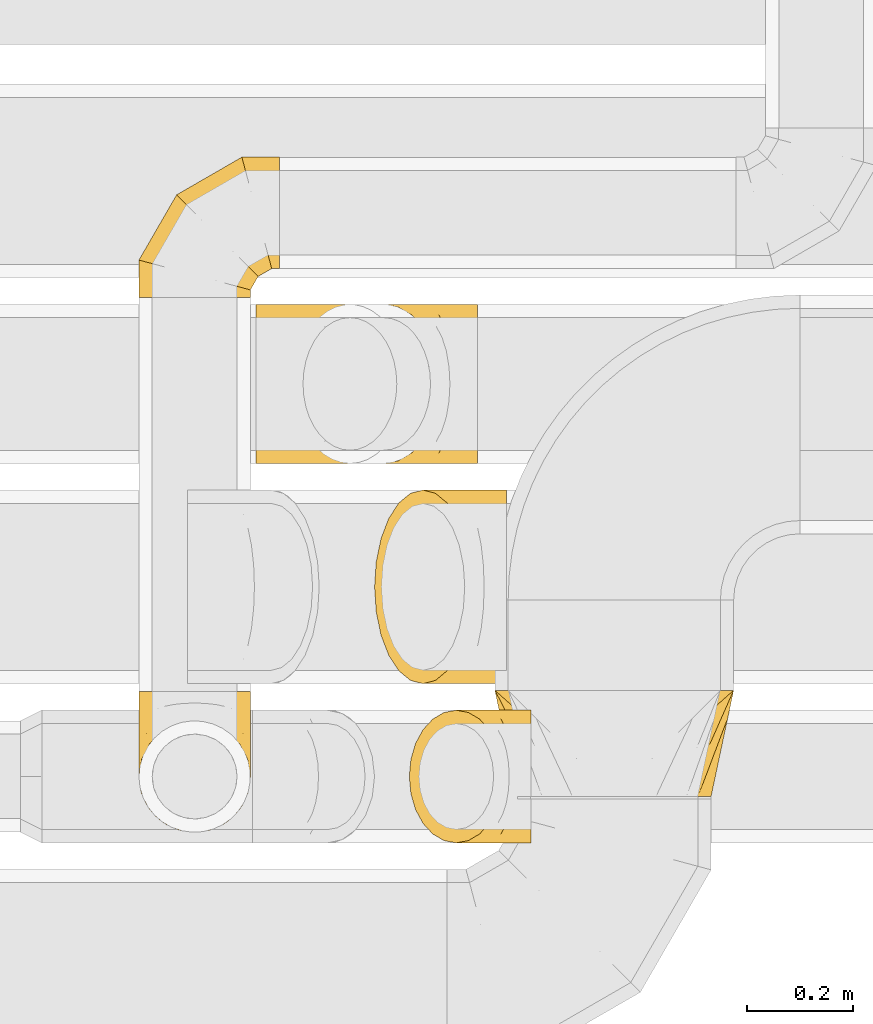
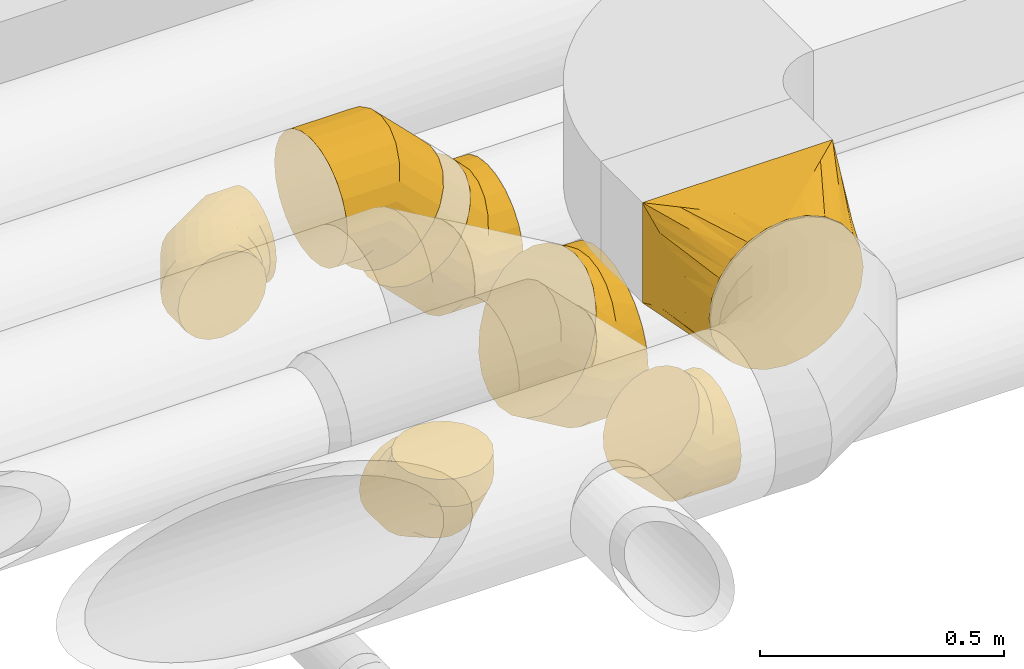
# One storey, part 18 of 92: 7 coverings.
"""IFC2X3 building model written with IfcOpenShell, lengths in millimetres."""

from ifc_helpers import new_model, entity, si_unit, converted_unit, derived_unit, direction, frame, origin, place, context, subcontext, project, spatial, faceted_brep, element, save


model = new_model("IFC2X3")

# Units and contexts
model_context = context("Model", 3, precision=0.01, world=origin(), true_north=direction((6.12303176911189e-17, 1.0)))
body_context = subcontext(model_context, "Body", "Model", "MODEL_VIEW")
ifc_project = project(units=[si_unit("LENGTHUNIT", "METRE", prefix="MILLI"), si_unit("AREAUNIT", "SQUARE_METRE"), si_unit("VOLUMEUNIT", "CUBIC_METRE"), converted_unit("PLANEANGLEUNIT", "DEGREE", entity("IfcRatioMeasure", 0.0174532925199433), si_unit("PLANEANGLEUNIT", "RADIAN"), dimensions=[0, 0, 0, 0, 0, 0, 0]), si_unit("MASSUNIT", "GRAM", prefix="KILO"), derived_unit("MASSDENSITYUNIT", [(si_unit("MASSUNIT", "GRAM", prefix="KILO"), 1), (si_unit("LENGTHUNIT", "METRE"), -3)]), derived_unit("MOMENTOFINERTIAUNIT", [(si_unit("LENGTHUNIT", "METRE"), 4)]), si_unit("TIMEUNIT", "SECOND"), si_unit("FREQUENCYUNIT", "HERTZ"), si_unit("THERMODYNAMICTEMPERATUREUNIT", "DEGREE_CELSIUS"), derived_unit("THERMALTRANSMITTANCEUNIT", [(si_unit("MASSUNIT", "GRAM", prefix="KILO"), 1), (si_unit("THERMODYNAMICTEMPERATUREUNIT", "KELVIN"), -1), (si_unit("TIMEUNIT", "SECOND"), -3)]), derived_unit("VOLUMETRICFLOWRATEUNIT", [(si_unit("LENGTHUNIT", "METRE"), 3), (si_unit("TIMEUNIT", "SECOND"), -1)]), derived_unit("MASSFLOWRATEUNIT", [(si_unit("MASSUNIT", "GRAM", prefix="KILO"), 1), (si_unit("TIMEUNIT", "SECOND"), -1)]), derived_unit("ROTATIONALFREQUENCYUNIT", [(si_unit("TIMEUNIT", "SECOND"), -1)]), si_unit("ELECTRICCURRENTUNIT", "AMPERE"), si_unit("ELECTRICVOLTAGEUNIT", "VOLT"), si_unit("POWERUNIT", "WATT"), si_unit("FORCEUNIT", "NEWTON", prefix="KILO"), si_unit("ILLUMINANCEUNIT", "LUX"), si_unit("LUMINOUSFLUXUNIT", "LUMEN"), si_unit("LUMINOUSINTENSITYUNIT", "CANDELA"), derived_unit("USERDEFINED", [(si_unit("MASSUNIT", "GRAM", prefix="KILO"), -1), (si_unit("LENGTHUNIT", "METRE"), -2), (si_unit("TIMEUNIT", "SECOND"), 3), (si_unit("LUMINOUSFLUXUNIT", "LUMEN"), 1)]), derived_unit("LINEARVELOCITYUNIT", [(si_unit("LENGTHUNIT", "METRE"), 1), (si_unit("TIMEUNIT", "SECOND"), -1)]), si_unit("PRESSUREUNIT", "PASCAL"), derived_unit("USERDEFINED", [(si_unit("LENGTHUNIT", "METRE"), -2), (si_unit("MASSUNIT", "GRAM", prefix="KILO"), 1), (si_unit("TIMEUNIT", "SECOND"), -2)]), derived_unit("LINEARFORCEUNIT", [(si_unit("MASSUNIT", "GRAM", prefix="KILO"), 1), (si_unit("LENGTHUNIT", "METRE"), 1), (si_unit("TIMEUNIT", "SECOND"), -2), (si_unit("LENGTHUNIT", "METRE"), -1)]), derived_unit("PLANARFORCEUNIT", [(si_unit("MASSUNIT", "GRAM", prefix="KILO"), 1), (si_unit("LENGTHUNIT", "METRE"), 1), (si_unit("TIMEUNIT", "SECOND"), -2), (si_unit("LENGTHUNIT", "METRE"), -2)])], contexts=[model_context])

# Site, building, storey
site_placement = place(None, origin())
site = spatial("IfcSite", under=ifc_project, at=site_placement, CompositionType="ELEMENT")
building_placement = place(site_placement, origin())
building = spatial("IfcBuilding", under=site, at=building_placement, CompositionType="ELEMENT")
storey_placement = place(building_placement, frame((0.0, 0.0, 4200.0)))
storey = spatial("IfcBuildingStorey", under=building, at=storey_placement, CompositionType="ELEMENT", Elevation=4200.0)

# Coverings
covering_1_placement = place(storey_placement, frame((46995.11, 14562.0, 3115.9)))
element("IfcCovering", 1, at=covering_1_placement, inside=storey, PredefinedType="INSULATION", context=body_context, shape_type="Brep", body=[
    faceted_brep([(316.25, 0.0, 342.14), (294.24, 0.0, 351.26), (272.23, 0.0, 360.38), (257.36, 0.0, 362.33), (242.49, 0.0, 364.29), (225.0, 0.0, 366.6), (207.51, 0.0, 364.29), (192.64, 0.0, 362.33), (177.77, 0.0, 360.38), (155.76, 0.0, 351.26), (133.75, 0.0, 342.14), (114.85, 0.0, 327.64), (95.95, 0.0, 313.14), (81.45, 0.0, 294.24), (66.95, 0.0, 275.35), (57.83, 0.0, 253.34), (48.72, 0.0, 231.33), (46.76, 0.0, 216.46), (44.8, 0.0, 201.59), (42.5, 0.0, 184.1), (44.8, 0.0, 166.6), (46.76, 0.0, 151.73), (48.72, 0.0, 136.86), (57.83, 0.0, 114.85), (66.95, 0.0, 92.85), (81.45, 0.0, 73.95), (95.95, 0.0, 55.05), (114.85, 0.0, 40.55), (133.75, 0.0, 26.05), (155.76, 0.0, 16.93), (177.77, 0.0, 7.81), (192.64, 0.0, 5.86), (207.51, 0.0, 3.9), (225.0, 0.0, 1.6), (242.49, 0.0, 3.9), (257.36, 0.0, 5.86), (272.23, 0.0, 7.81), (294.24, 0.0, 16.93), (316.25, 0.0, 26.05), (335.15, 0.0, 40.55), (354.05, 0.0, 55.05), (368.55, 0.0, 73.95), (383.05, 0.0, 92.85), (392.17, 0.0, 114.85), (401.28, 0.0, 136.86), (403.24, 0.0, 151.73), (405.2, 0.0, 166.6), (407.5, 0.0, 184.1), (405.2, 0.0, 201.59), (403.24, 0.0, 216.46), (401.28, 0.0, 231.33), (392.17, 0.0, 253.34), (383.05, 0.0, 275.35), (368.55, 0.0, 294.24), (354.05, 0.0, 313.14), (335.15, 0.0, 327.64), (450.0, 200.0, 366.6), (450.0, 200.0, 116.6), (0.0, 200.0, 116.6), (0.0, 200.0, 366.6), (305.9, 71.91, 42.95), (332.87, 95.89, 56.73), (362.15, 121.91, 71.7), (398.0, 100.0, 82.03), (420.72, 173.97, 101.63), (438.94, 147.94, 134.16), (444.47, 173.97, 125.38), (433.41, 121.91, 142.95), (427.88, 95.89, 151.73), (422.78, 71.91, 159.82), (251.97, 23.97, 15.38), (278.94, 47.94, 29.16), (417.69, 47.94, 167.91), (412.59, 23.97, 176.0), (391.44, 147.94, 86.66), (444.47, 173.97, 342.84), (438.94, 147.94, 319.09), (433.41, 121.91, 295.34), (427.88, 95.89, 271.59), (422.78, 71.91, 249.72), (417.69, 47.94, 227.84), (412.59, 23.97, 205.97), (405.81, 100.0, 335.85), (391.44, 147.94, 366.6), (420.72, 173.97, 366.6), (362.15, 121.91, 366.6), (332.87, 95.89, 366.6), (305.9, 71.91, 366.6), (278.94, 47.94, 366.6), (251.97, 23.97, 366.6), (29.28, 173.97, 366.6), (58.56, 147.94, 366.6), (87.85, 121.91, 366.6), (117.13, 95.89, 366.6), (144.1, 71.91, 366.6), (171.06, 47.94, 366.6), (198.03, 23.97, 366.6), (52.0, 100.0, 343.66), (11.06, 147.94, 319.09), (5.53, 173.97, 342.84), (16.59, 121.91, 295.34), (22.12, 95.89, 271.59), (27.22, 71.91, 249.72), (32.31, 47.94, 227.84), (37.41, 23.97, 205.97), (5.53, 173.97, 125.38), (11.06, 147.94, 134.16), (16.59, 121.91, 142.95), (22.12, 95.89, 151.73), (27.22, 71.91, 159.82), (32.31, 47.94, 167.91), (37.41, 23.97, 176.0), (44.19, 100.0, 89.85), (58.56, 147.94, 86.66), (29.28, 173.97, 101.63), (87.85, 121.91, 71.7), (117.13, 95.89, 56.73), (144.1, 71.91, 42.95), (171.06, 47.94, 29.16), (198.03, 23.97, 15.38)], [[[0, 1, 2, 3, 4, 5, 6, 7, 8, 9, 10, 11, 12, 13, 14, 15, 16, 17, 18, 19, 20, 21, 22, 23, 24, 25, 26, 27, 28, 29, 30, 31, 32, 33, 34, 35, 36, 37, 38, 39, 40, 41, 42, 43, 44, 45, 46, 47, 48, 49, 50, 51, 52, 53, 54, 55]], [[56, 57, 58, 59]], [[60, 61, 62, 37]], [[63, 39, 64]], [[41, 40, 63]], [[36, 60, 37]], [[37, 62, 38]], [[65, 42, 41]], [[41, 63, 66]], [[43, 67, 68, 69]], [[70, 71, 60, 36, 35, 34, 33]], [[45, 44, 69, 72, 73, 47, 46]], [[43, 42, 67]], [[43, 69, 44]], [[42, 65, 67]], [[39, 74, 64]], [[39, 38, 74]], [[57, 63, 64]], [[39, 63, 40]], [[41, 66, 65]], [[63, 57, 66]], [[62, 74, 38]], [[57, 56, 75, 76, 77, 78, 79, 80, 81, 47, 73, 72, 69, 68, 67, 65, 66]], [[79, 78, 77, 51]], [[82, 53, 75]], [[55, 54, 82]], [[50, 79, 51]], [[51, 77, 52]], [[83, 0, 55]], [[55, 82, 84]], [[1, 85, 86, 87]], [[81, 80, 79, 50, 49, 48, 47]], [[3, 2, 87, 88, 89, 5, 4]], [[1, 0, 85]], [[1, 87, 2]], [[0, 83, 85]], [[53, 76, 75]], [[53, 52, 76]], [[56, 82, 75]], [[53, 82, 54]], [[55, 84, 83]], [[82, 56, 84]], [[77, 76, 52]], [[56, 59, 90, 91, 92, 93, 94, 95, 96, 5, 89, 88, 87, 86, 85, 83, 84]], [[94, 93, 92, 9]], [[97, 11, 90]], [[13, 12, 97]], [[8, 94, 9]], [[9, 92, 10]], [[98, 14, 13]], [[13, 97, 99]], [[15, 100, 101, 102]], [[96, 95, 94, 8, 7, 6, 5]], [[17, 16, 102, 103, 104, 19, 18]], [[15, 14, 100]], [[15, 102, 16]], [[14, 98, 100]], [[11, 91, 90]], [[11, 10, 91]], [[59, 97, 90]], [[11, 97, 12]], [[13, 99, 98]], [[97, 59, 99]], [[92, 91, 10]], [[104, 103, 102, 101, 100, 98, 99, 59, 58, 105, 106, 107, 108, 109, 110, 111, 19]], [[109, 108, 107, 23]], [[112, 25, 105]], [[27, 26, 112]], [[22, 109, 23]], [[23, 107, 24]], [[113, 28, 27]], [[27, 112, 114]], [[29, 115, 116, 117]], [[111, 110, 109, 22, 21, 20, 19]], [[31, 30, 117, 118, 119, 33, 32]], [[29, 28, 115]], [[29, 117, 30]], [[28, 113, 115]], [[25, 106, 105]], [[25, 24, 106]], [[58, 112, 105]], [[25, 112, 26]], [[27, 114, 113]], [[112, 58, 114]], [[107, 106, 24]], [[58, 57, 64, 74, 62, 61, 60, 71, 70, 33, 119, 118, 117, 116, 115, 113, 114]]]),
])
covering_2_placement = place(storey_placement, frame((46677.74, 15187.9, 2938.4)))
element("IfcCovering", 2, at=covering_2_placement, inside=storey, PredefinedType="INSULATION", context=body_context, shape_type="Brep", body=[
    faceted_brep([(284.44, 151.6, 301.6), (284.44, 112.77, 296.48), (284.44, 76.6, 281.5), (284.44, 45.53, 257.66), (284.44, 21.69, 226.6), (284.44, 6.71, 190.42), (284.44, 1.6, 151.6), (284.44, 6.71, 112.77), (284.44, 21.69, 76.6), (284.44, 45.53, 45.53), (284.44, 76.6, 21.69), (284.44, 112.77, 6.71), (284.44, 151.6, 1.6), (284.44, 190.42, 6.71), (284.44, 226.6, 21.69), (284.44, 257.66, 45.53), (284.44, 281.5, 76.6), (284.44, 296.48, 112.77), (284.44, 301.6, 151.6), (284.44, 296.48, 190.42), (284.44, 281.5, 226.6), (284.44, 257.66, 257.66), (284.44, 226.6, 281.5), (284.44, 190.42, 296.48), (15.81, 226.6, 132.96), (5.21, 190.42, 122.37), (1.6, 151.6, 118.75), (5.21, 112.77, 122.37), (15.81, 76.6, 132.96), (32.66, 45.53, 149.82), (54.63, 21.69, 171.79), (80.21, 6.71, 197.37), (107.66, 1.6, 224.82), (135.11, 6.71, 252.27), (160.69, 21.69, 277.85), (182.66, 45.53, 299.82), (199.52, 76.6, 316.67), (210.11, 112.77, 327.27), (213.73, 151.6, 330.88), (210.11, 190.42, 327.27), (199.52, 226.6, 316.67), (182.66, 257.66, 299.82), (160.69, 281.5, 277.85), (135.11, 296.48, 252.27), (107.66, 301.6, 224.82), (80.21, 296.48, 197.37), (54.63, 281.5, 171.79), (32.66, 257.66, 149.82), (118.75, 151.6, 1.6), (120.87, 112.77, 6.71), (127.08, 76.6, 21.69), (136.95, 45.53, 45.53), (149.82, 21.69, 76.6), (164.8, 6.71, 112.77), (180.88, 1.6, 151.6), (196.97, 6.71, 190.42), (211.95, 21.69, 226.6), (224.82, 45.53, 257.66), (240.9, 112.77, 296.48), (243.02, 151.6, 301.6), (234.69, 76.6, 281.5), (234.69, 226.6, 281.5), (224.82, 257.66, 257.66), (240.9, 190.42, 296.48), (196.97, 296.48, 190.42), (180.88, 301.6, 151.6), (211.95, 281.5, 226.6), (164.8, 296.48, 112.77), (149.82, 281.5, 76.6), (136.95, 257.66, 45.53), (127.08, 226.6, 21.69), (120.87, 190.42, 6.71)], [[[0, 1, 2, 3, 4, 5, 6, 7, 8, 9, 10, 11, 12, 13, 14, 15, 16, 17, 18, 19, 20, 21, 22, 23]], [[24, 25, 26, 27, 28, 29, 30, 31, 32, 33, 34, 35, 36, 37, 38, 39, 40, 41, 42, 43, 44, 45, 46, 47]], [[26, 48, 49, 27]], [[27, 49, 50, 28]], [[51, 29, 28, 50]], [[29, 51, 52, 30]], [[30, 52, 53, 31]], [[54, 32, 31, 53]], [[55, 56, 34, 33]], [[54, 55, 33, 32]], [[34, 56, 57, 35]], [[58, 59, 38, 37]], [[60, 58, 37, 36]], [[35, 57, 60, 36]], [[40, 61, 62, 41]], [[63, 61, 40, 39]], [[38, 59, 63, 39]], [[64, 65, 44, 43]], [[66, 64, 43, 42]], [[62, 66, 42, 41]], [[45, 44, 65, 67]], [[46, 45, 67, 68]], [[68, 69, 47, 46]], [[25, 24, 70, 71]], [[26, 25, 71, 48]], [[69, 70, 24, 47]], [[11, 10, 50, 49]], [[12, 11, 49, 48]], [[10, 9, 51, 50]], [[53, 52, 8, 7]], [[54, 53, 7, 6]], [[9, 8, 52, 51]], [[5, 4, 56, 55]], [[6, 5, 55, 54]], [[57, 56, 4, 3]], [[58, 60, 2, 1]], [[59, 58, 1, 0]], [[3, 2, 60, 57]], [[59, 0, 23, 63]], [[63, 23, 22, 61]], [[21, 62, 61, 22]], [[66, 20, 19, 64]], [[64, 19, 18, 65]], [[20, 66, 62, 21]], [[65, 18, 17, 67]], [[67, 17, 16, 68]], [[15, 69, 68, 16]], [[70, 14, 13, 71]], [[71, 13, 12, 48]], [[14, 70, 69, 15]]]),
])
covering_3_placement = place(storey_placement, frame((46832.17, 14472.9, 2873.4)))
element("IfcCovering", 3, at=covering_3_placement, inside=storey, PredefinedType="INSULATION", context=body_context, shape_type="Brep", body=[
    faceted_brep([(231.4, 165.22, 245.48), (231.4, 126.6, 251.6), (231.4, 87.97, 245.48), (231.4, 53.12, 227.72), (231.4, 25.47, 200.07), (231.4, 7.71, 165.22), (231.4, 1.6, 126.6), (231.4, 7.71, 87.97), (231.4, 25.47, 53.12), (231.4, 53.12, 25.47), (231.4, 87.97, 7.71), (231.4, 126.6, 1.6), (231.4, 165.22, 7.71), (231.4, 200.07, 25.47), (231.4, 227.72, 53.12), (231.4, 245.48, 87.97), (231.4, 251.6, 126.6), (231.4, 245.48, 165.22), (231.4, 227.72, 200.07), (231.4, 200.07, 227.72), (4.61, 158.95, 99.8), (1.6, 126.6, 96.79), (4.61, 94.24, 99.8), (13.44, 64.1, 108.63), (27.48, 38.21, 122.67), (45.79, 18.34, 140.98), (67.11, 5.85, 162.3), (89.98, 1.6, 185.17), (112.86, 5.85, 208.05), (134.18, 18.34, 229.37), (152.48, 38.21, 247.67), (166.53, 64.1, 261.72), (175.36, 94.24, 270.55), (178.37, 126.6, 273.56), (175.36, 158.95, 270.55), (166.53, 189.1, 261.72), (152.48, 214.98, 247.67), (134.18, 234.85, 229.37), (112.86, 247.34, 208.05), (89.98, 251.6, 185.17), (67.11, 247.34, 162.3), (45.79, 234.85, 140.98), (27.48, 214.98, 122.67), (13.44, 189.1, 108.63), (96.79, 126.6, 1.6), (98.55, 94.24, 5.85), (103.72, 64.1, 18.34), (111.95, 38.21, 38.21), (122.67, 18.34, 64.1), (135.16, 5.85, 94.24), (148.56, 1.6, 126.6), (161.96, 5.85, 158.95), (174.45, 18.34, 189.1), (185.17, 38.21, 214.98), (198.57, 94.24, 247.34), (200.34, 126.6, 251.6), (193.4, 64.1, 234.85), (193.4, 189.1, 234.85), (185.17, 214.98, 214.98), (198.57, 158.95, 247.34), (161.96, 247.34, 158.95), (148.56, 251.6, 126.6), (174.45, 234.85, 189.1), (135.16, 247.34, 94.24), (122.67, 234.85, 64.1), (111.95, 214.98, 38.21), (103.72, 189.1, 18.34), (98.55, 158.95, 5.85)], [[[0, 1, 2, 3, 4, 5, 6, 7, 8, 9, 10, 11, 12, 13, 14, 15, 16, 17, 18, 19]], [[20, 21, 22, 23, 24, 25, 26, 27, 28, 29, 30, 31, 32, 33, 34, 35, 36, 37, 38, 39, 40, 41, 42, 43]], [[21, 44, 45, 22]], [[22, 45, 46, 23]], [[47, 24, 23, 46]], [[24, 47, 48, 25]], [[25, 48, 49, 26]], [[50, 27, 26, 49]], [[51, 52, 29, 28]], [[50, 51, 28, 27]], [[29, 52, 53, 30]], [[54, 55, 33, 32]], [[56, 54, 32, 31]], [[30, 53, 56, 31]], [[35, 57, 58, 36]], [[59, 57, 35, 34]], [[33, 55, 59, 34]], [[60, 61, 39, 38]], [[62, 60, 38, 37]], [[58, 62, 37, 36]], [[40, 39, 61, 63]], [[41, 40, 63, 64]], [[64, 65, 42, 41]], [[20, 43, 66, 67]], [[21, 20, 67, 44]], [[65, 66, 43, 42]], [[10, 9, 46]], [[11, 10, 45]], [[11, 45, 44]], [[45, 10, 46]], [[9, 47, 46]], [[48, 8, 7]], [[49, 7, 6]], [[47, 8, 48]], [[48, 7, 49]], [[6, 50, 49]], [[8, 47, 9]], [[5, 4, 52]], [[6, 5, 51]], [[51, 50, 6]], [[52, 51, 5]], [[4, 53, 52]], [[56, 3, 2]], [[54, 2, 1]], [[56, 53, 3]], [[55, 54, 1]], [[56, 2, 54]], [[3, 53, 4]], [[0, 19, 57]], [[1, 0, 59]], [[59, 55, 1]], [[57, 59, 0]], [[19, 58, 57]], [[62, 18, 17]], [[60, 17, 16]], [[62, 58, 18]], [[61, 60, 16]], [[62, 17, 60]], [[18, 58, 19]], [[63, 16, 15]], [[64, 15, 14]], [[16, 63, 61]], [[63, 15, 64]], [[14, 65, 64]], [[66, 13, 12]], [[67, 12, 11]], [[65, 13, 66]], [[67, 66, 12]], [[44, 67, 11]], [[13, 65, 14]]]),
])
covering_4_placement = place(storey_placement, frame((46766.74, 14772.9, 2865.9)))
element("IfcCovering", 4, at=covering_4_placement, inside=storey, PredefinedType="INSULATION", context=body_context, shape_type="Brep", body=[
    faceted_brep([(180.99, 231.33, 378.96), (171.87, 275.35, 363.17), (157.37, 313.14, 338.06), (138.47, 342.14, 305.32), (116.46, 360.38, 267.2), (92.85, 366.6, 226.3), (69.23, 360.38, 185.39), (47.22, 342.14, 147.27), (28.32, 313.14, 114.54), (13.82, 275.35, 89.42), (4.7, 231.33, 73.63), (1.6, 184.1, 68.25), (4.7, 136.86, 73.63), (13.82, 92.85, 89.42), (28.32, 55.05, 114.54), (47.22, 26.05, 147.27), (69.23, 7.81, 185.39), (92.85, 1.6, 226.3), (116.46, 7.81, 267.2), (138.47, 26.05, 305.32), (157.37, 55.05, 338.06), (171.87, 92.85, 363.17), (180.99, 136.86, 378.96), (184.1, 184.1, 384.35), (250.35, 92.85, 26.05), (250.35, 136.86, 7.81), (250.35, 184.1, 1.6), (250.35, 231.33, 7.81), (250.35, 275.35, 26.05), (250.35, 313.14, 55.05), (250.35, 342.14, 92.85), (250.35, 360.38, 136.86), (250.35, 366.6, 184.1), (250.35, 360.38, 231.33), (250.35, 342.14, 275.35), (250.35, 313.14, 313.14), (250.35, 275.35, 342.14), (250.35, 231.33, 360.38), (250.35, 184.1, 366.6), (250.35, 136.86, 360.38), (250.35, 92.85, 342.14), (250.35, 55.05, 313.14), (250.35, 26.05, 275.35), (250.35, 7.81, 231.33), (250.35, 1.6, 184.1), (250.35, 7.81, 136.86), (250.35, 26.05, 92.85), (250.35, 55.05, 55.05), (117.04, 184.1, 1.6), (118.27, 224.71, 6.17), (121.88, 263.28, 19.67), (127.71, 297.88, 41.41), (135.45, 326.78, 70.31), (144.72, 348.52, 104.91), (155.06, 362.02, 143.49), (165.94, 366.6, 184.1), (176.82, 362.02, 224.71), (187.16, 348.52, 263.28), (196.43, 326.78, 297.88), (204.17, 297.88, 326.78), (210.0, 263.28, 348.52), (213.62, 224.71, 362.02), (214.84, 184.1, 366.6), (210.0, 104.91, 348.52), (204.17, 70.31, 326.78), (213.62, 143.49, 362.02), (196.43, 41.41, 297.88), (187.16, 19.67, 263.28), (176.82, 6.17, 224.71), (165.94, 1.6, 184.1), (155.06, 6.17, 143.49), (144.72, 19.67, 104.91), (135.45, 41.41, 70.31), (127.71, 70.31, 41.41), (121.88, 104.91, 19.67), (118.27, 143.49, 6.17)], [[[0, 1, 2, 3, 4, 5, 6, 7, 8, 9, 10, 11, 12, 13, 14, 15, 16, 17, 18, 19, 20, 21, 22, 23]], [[24, 25, 26, 27, 28, 29, 30, 31, 32, 33, 34, 35, 36, 37, 38, 39, 40, 41, 42, 43, 44, 45, 46, 47]], [[26, 48, 49]], [[27, 49, 50]], [[26, 49, 27]], [[28, 51, 29]], [[28, 27, 50]], [[51, 28, 50]], [[30, 52, 53]], [[31, 53, 54]], [[32, 54, 55]], [[29, 52, 30]], [[30, 53, 31]], [[54, 32, 31]], [[52, 29, 51]], [[56, 57, 33]], [[55, 56, 32]], [[32, 56, 33]], [[34, 58, 35]], [[34, 33, 57]], [[58, 34, 57]], [[59, 60, 36]], [[61, 62, 38]], [[60, 61, 37]], [[35, 59, 36]], [[36, 60, 37]], [[61, 38, 37]], [[59, 35, 58]], [[63, 64, 40]], [[65, 63, 39]], [[62, 65, 38]], [[38, 65, 39]], [[63, 40, 39]], [[64, 41, 40]], [[66, 67, 42]], [[68, 69, 44]], [[67, 68, 43]], [[41, 66, 42]], [[42, 67, 43]], [[68, 44, 43]], [[66, 41, 64]], [[45, 70, 71]], [[46, 71, 72]], [[69, 70, 44]], [[44, 70, 45]], [[71, 46, 45]], [[72, 47, 46]], [[24, 73, 74]], [[74, 75, 25]], [[48, 26, 75]], [[47, 73, 24]], [[24, 74, 25]], [[75, 26, 25]], [[73, 47, 72]], [[49, 11, 10]], [[50, 10, 9]], [[48, 11, 49]], [[49, 10, 50]], [[9, 51, 50]], [[9, 8, 51]], [[52, 8, 7]], [[53, 7, 6]], [[54, 6, 5]], [[52, 7, 53]], [[53, 6, 54]], [[5, 55, 54]], [[8, 52, 51]], [[56, 5, 4]], [[57, 4, 3]], [[56, 55, 5]], [[58, 57, 3]], [[56, 4, 57]], [[3, 2, 58]], [[59, 2, 1]], [[60, 1, 0]], [[61, 0, 23]], [[60, 59, 1]], [[62, 61, 23]], [[60, 0, 61]], [[2, 59, 58]], [[65, 23, 22]], [[63, 22, 21]], [[65, 62, 23]], [[64, 63, 21]], [[65, 22, 63]], [[21, 20, 64]], [[66, 20, 19]], [[67, 19, 18]], [[68, 18, 17]], [[67, 66, 19]], [[69, 68, 17]], [[67, 18, 68]], [[20, 66, 64]], [[70, 17, 16]], [[71, 16, 15]], [[69, 17, 70]], [[71, 70, 16]], [[72, 71, 15]], [[15, 14, 72]], [[73, 14, 13]], [[74, 13, 12]], [[75, 12, 11]], [[73, 13, 74]], [[75, 74, 12]], [[48, 75, 11]], [[14, 73, 72]]]),
])
covering_5_placement = place(storey_placement, frame((46322.59, 15501.98, 2893.4)))
element("IfcCovering", 5, at=covering_5_placement, inside=storey, PredefinedType="INSULATION", context=body_context, shape_type="Brep", body=[
    faceted_brep([(106.6, 0.0, 211.6), (74.15, 0.0, 206.46), (44.88, 0.0, 191.54), (21.65, 0.0, 168.31), (6.73, 0.0, 139.04), (1.6, 0.0, 106.6), (6.73, 0.0, 74.15), (21.65, 0.0, 44.88), (44.88, 0.0, 21.65), (74.15, 0.0, 6.73), (106.6, 0.0, 1.6), (139.04, 0.0, 6.73), (168.31, 0.0, 21.65), (191.54, 0.0, 44.88), (206.46, 0.0, 74.15), (211.6, 0.0, 106.6), (206.46, 0.0, 139.04), (191.54, 0.0, 168.31), (168.31, 0.0, 191.54), (139.04, 0.0, 206.46), (266.6, 250.93, 54.1), (266.6, 261.42, 79.42), (266.6, 265.0, 106.6), (266.6, 261.42, 133.77), (266.6, 250.93, 159.1), (266.6, 234.25, 180.84), (266.6, 212.5, 197.53), (266.6, 187.18, 208.02), (266.6, 160.0, 211.6), (266.6, 132.82, 208.02), (266.6, 107.5, 197.53), (266.6, 85.75, 180.84), (266.6, 69.07, 159.1), (266.6, 58.58, 133.77), (266.6, 55.0, 106.6), (266.6, 58.58, 79.42), (266.6, 69.07, 54.1), (266.6, 85.75, 32.35), (266.6, 107.5, 15.66), (266.6, 132.82, 5.17), (266.6, 160.0, 1.6), (266.6, 187.18, 5.17), (266.6, 212.5, 15.66), (266.6, 234.25, 32.35), (195.59, 265.0, 106.6), (196.55, 261.42, 133.77), (199.36, 250.93, 159.1), (203.83, 234.25, 180.84), (209.66, 212.5, 197.53), (216.44, 187.18, 208.02), (223.72, 160.0, 211.6), (231.01, 132.82, 208.02), (237.79, 107.5, 197.53), (243.62, 85.75, 180.84), (248.09, 69.07, 159.1), (250.9, 58.58, 133.77), (251.86, 55.0, 106.6), (250.9, 58.58, 79.42), (248.09, 69.07, 54.1), (243.62, 85.75, 32.35), (231.01, 132.82, 5.17), (223.72, 160.0, 1.6), (237.79, 107.5, 15.66), (216.44, 187.18, 5.17), (209.66, 212.5, 15.66), (203.83, 234.25, 32.35), (199.36, 250.93, 54.1), (196.55, 261.42, 79.42), (72.6, 193.99, 106.6), (75.22, 191.37, 133.77), (82.9, 183.7, 159.1), (95.12, 171.48, 180.84), (111.03, 155.56, 197.53), (129.57, 137.02, 208.02), (149.47, 117.13, 211.6), (169.36, 97.23, 208.02), (187.9, 78.7, 197.53), (203.82, 62.78, 180.84), (216.03, 50.56, 159.1), (223.71, 42.88, 133.77), (226.33, 40.26, 106.6), (223.71, 42.88, 79.42), (216.03, 50.56, 54.1), (203.82, 62.78, 32.35), (169.36, 97.23, 5.17), (149.47, 117.13, 1.6), (187.9, 78.7, 15.66), (129.57, 137.02, 5.17), (111.03, 155.56, 15.66), (95.12, 171.48, 32.35), (82.9, 183.7, 54.1), (75.22, 191.37, 79.42), (1.6, 71.01, 106.6), (5.17, 70.05, 133.77), (15.66, 67.24, 159.1), (32.35, 62.77, 180.84), (54.1, 56.94, 197.53), (79.42, 50.15, 208.02), (106.6, 42.87, 211.6), (133.77, 35.59, 208.02), (159.1, 28.8, 197.53), (180.84, 22.98, 180.84), (197.53, 18.51, 159.1), (208.02, 15.7, 133.77), (211.6, 14.74, 106.6), (208.02, 15.7, 79.42), (197.53, 18.51, 54.1), (180.84, 22.98, 32.35), (133.77, 35.59, 5.17), (106.6, 42.87, 1.6), (159.1, 28.8, 15.66), (79.42, 50.15, 5.17), (54.1, 56.94, 15.66), (32.35, 62.77, 32.35), (15.66, 67.24, 54.1), (5.17, 70.05, 79.42)], [[[0, 1, 2, 3, 4, 5, 6, 7, 8, 9, 10, 11, 12, 13, 14, 15, 16, 17, 18, 19]], [[20, 21, 22, 23, 24, 25, 26, 27, 28, 29, 30, 31, 32, 33, 34, 35, 36, 37, 38, 39, 40, 41, 42, 43]], [[22, 44, 45, 23]], [[23, 45, 46, 24]], [[24, 46, 47, 25]], [[25, 47, 48, 26]], [[26, 48, 49, 27]], [[50, 28, 27, 49]], [[51, 52, 30, 29]], [[50, 51, 29, 28]], [[53, 31, 30, 52]], [[54, 55, 33, 32]], [[54, 32, 31, 53]], [[56, 34, 33, 55]], [[57, 58, 36, 35]], [[56, 57, 35, 34]], [[37, 36, 58, 59]], [[60, 61, 40, 39]], [[62, 60, 39, 38]], [[59, 62, 38, 37]], [[41, 40, 61, 63]], [[42, 41, 63, 64]], [[64, 65, 43, 42]], [[21, 20, 66, 67]], [[22, 21, 67, 44]], [[65, 66, 20, 43]], [[45, 44, 68, 69]], [[46, 45, 69, 70]], [[70, 71, 47, 46]], [[48, 47, 71, 72]], [[49, 48, 72, 73]], [[50, 49, 73, 74]], [[75, 76, 52, 51]], [[74, 75, 51, 50]], [[53, 52, 76, 77]], [[78, 79, 55, 54]], [[77, 78, 54, 53]], [[56, 55, 79, 80]], [[81, 82, 58, 57]], [[80, 81, 57, 56]], [[59, 58, 82, 83]], [[84, 85, 61, 60]], [[86, 84, 60, 62]], [[83, 86, 62, 59]], [[63, 61, 85, 87]], [[64, 63, 87, 88]], [[65, 64, 88, 89]], [[67, 66, 90, 91]], [[44, 67, 91, 68]], [[89, 90, 66, 65]], [[69, 68, 92, 93]], [[70, 69, 93, 94]], [[94, 95, 71, 70]], [[72, 71, 95, 96]], [[73, 72, 96, 97]], [[74, 73, 97, 98]], [[99, 100, 76, 75]], [[98, 99, 75, 74]], [[77, 76, 100, 101]], [[102, 103, 79, 78]], [[101, 102, 78, 77]], [[80, 79, 103, 104]], [[105, 106, 82, 81]], [[104, 105, 81, 80]], [[83, 82, 106, 107]], [[108, 109, 85, 84]], [[110, 108, 84, 86]], [[107, 110, 86, 83]], [[87, 85, 109, 111]], [[88, 87, 111, 112]], [[89, 88, 112, 113]], [[91, 90, 114, 115]], [[68, 91, 115, 92]], [[113, 114, 90, 89]], [[93, 5, 4]], [[94, 4, 3]], [[5, 93, 92]], [[93, 4, 94]], [[3, 95, 94]], [[96, 2, 1]], [[97, 1, 0]], [[95, 2, 96]], [[96, 1, 97]], [[0, 98, 97]], [[2, 95, 3]], [[99, 0, 19]], [[100, 19, 18]], [[99, 98, 0]], [[100, 99, 19]], [[18, 101, 100]], [[102, 17, 16]], [[103, 16, 15]], [[102, 101, 17]], [[104, 103, 15]], [[102, 16, 103]], [[17, 101, 18]], [[105, 15, 14]], [[106, 14, 13]], [[105, 104, 15]], [[106, 105, 14]], [[13, 107, 106]], [[110, 12, 11]], [[108, 11, 10]], [[110, 107, 12]], [[109, 108, 10]], [[110, 11, 108]], [[12, 107, 13]], [[9, 8, 112]], [[10, 9, 111]], [[10, 111, 109]], [[111, 9, 112]], [[8, 113, 112]], [[114, 7, 6]], [[115, 6, 5]], [[113, 7, 114]], [[115, 114, 6]], [[92, 115, 5]], [[7, 113, 8]]]),
])
covering_6_placement = place(storey_placement, frame((46322.59, 14492.9, 2893.4)))
element("IfcCovering", 6, at=covering_6_placement, inside=storey, PredefinedType="INSULATION", context=body_context, shape_type="Brep", body=[
    faceted_brep([(1.6, 106.6, 266.6), (6.73, 74.15, 266.6), (21.65, 44.88, 266.6), (44.88, 21.65, 266.6), (74.15, 6.73, 266.6), (106.6, 1.6, 266.6), (139.04, 6.73, 266.6), (168.31, 21.65, 266.6), (191.54, 44.88, 266.6), (206.46, 74.15, 266.6), (211.6, 106.6, 266.6), (206.46, 139.04, 266.6), (191.54, 168.31, 266.6), (168.31, 191.54, 266.6), (139.04, 206.46, 266.6), (106.6, 211.6, 266.6), (74.15, 206.46, 266.6), (44.88, 191.54, 266.6), (21.65, 168.31, 266.6), (6.73, 139.04, 266.6), (159.1, 266.6, 15.66), (133.77, 266.6, 5.17), (106.6, 266.6, 1.6), (79.42, 266.6, 5.17), (54.1, 266.6, 15.66), (32.35, 266.6, 32.35), (15.66, 266.6, 54.1), (5.17, 266.6, 79.42), (1.6, 266.6, 106.6), (5.17, 266.6, 133.77), (15.66, 266.6, 159.1), (32.35, 266.6, 180.84), (54.1, 266.6, 197.53), (79.42, 266.6, 208.02), (106.6, 266.6, 211.6), (133.77, 266.6, 208.02), (159.1, 266.6, 197.53), (180.84, 266.6, 180.84), (197.53, 266.6, 159.1), (208.02, 266.6, 133.77), (211.6, 266.6, 106.6), (208.02, 266.6, 79.42), (197.53, 266.6, 54.1), (180.84, 266.6, 32.35), (106.6, 195.59, 1.6), (79.42, 196.55, 5.17), (54.1, 199.36, 15.66), (32.35, 203.83, 32.35), (15.66, 209.66, 54.1), (5.17, 216.44, 79.42), (1.6, 223.72, 106.6), (5.17, 231.01, 133.77), (15.66, 237.79, 159.1), (32.35, 243.62, 180.84), (54.1, 248.09, 197.53), (79.42, 250.9, 208.02), (106.6, 251.86, 211.6), (133.77, 250.9, 208.02), (159.1, 248.09, 197.53), (180.84, 243.62, 180.84), (208.02, 231.01, 133.77), (211.6, 223.72, 106.6), (197.53, 237.79, 159.1), (208.02, 216.44, 79.42), (197.53, 209.66, 54.1), (180.84, 203.83, 32.35), (159.1, 199.36, 15.66), (133.77, 196.55, 5.17), (106.6, 72.6, 72.6), (79.42, 75.22, 75.22), (54.1, 82.9, 82.9), (32.35, 95.12, 95.12), (15.66, 111.03, 111.03), (5.17, 129.57, 129.57), (1.6, 149.47, 149.47), (5.17, 169.36, 169.36), (15.66, 187.9, 187.9), (32.35, 203.82, 203.82), (54.1, 216.03, 216.03), (79.42, 223.71, 223.71), (106.6, 226.33, 226.33), (133.77, 223.71, 223.71), (159.1, 216.03, 216.03), (180.84, 203.82, 203.82), (208.02, 169.36, 169.36), (211.6, 149.47, 149.47), (197.53, 187.9, 187.9), (208.02, 129.57, 129.57), (197.53, 111.03, 111.03), (180.84, 95.12, 95.12), (159.1, 82.9, 82.9), (133.77, 75.22, 75.22), (106.6, 1.6, 195.59), (79.42, 5.17, 196.55), (54.1, 15.66, 199.36), (32.35, 32.35, 203.83), (15.66, 54.1, 209.66), (5.17, 79.42, 216.44), (1.6, 106.6, 223.72), (5.17, 133.77, 231.01), (15.66, 159.1, 237.79), (32.35, 180.84, 243.62), (54.1, 197.53, 248.09), (79.42, 208.02, 250.9), (106.6, 211.6, 251.86), (133.77, 208.02, 250.9), (159.1, 197.53, 248.09), (180.84, 180.84, 243.62), (208.02, 133.77, 231.01), (211.6, 106.6, 223.72), (197.53, 159.1, 237.79), (208.02, 79.42, 216.44), (197.53, 54.1, 209.66), (180.84, 32.35, 203.83), (159.1, 15.66, 199.36), (133.77, 5.17, 196.55)], [[[0, 1, 2, 3, 4, 5, 6, 7, 8, 9, 10, 11, 12, 13, 14, 15, 16, 17, 18, 19]], [[20, 21, 22, 23, 24, 25, 26, 27, 28, 29, 30, 31, 32, 33, 34, 35, 36, 37, 38, 39, 40, 41, 42, 43]], [[22, 44, 45, 23]], [[23, 45, 46, 24]], [[24, 46, 47, 25]], [[25, 47, 48, 26]], [[26, 48, 49, 27]], [[50, 28, 27, 49]], [[51, 52, 30, 29]], [[50, 51, 29, 28]], [[53, 31, 30, 52]], [[54, 55, 33, 32]], [[54, 32, 31, 53]], [[56, 34, 33, 55]], [[57, 58, 36, 35]], [[56, 57, 35, 34]], [[37, 36, 58, 59]], [[60, 61, 40, 39]], [[62, 60, 39, 38]], [[59, 62, 38, 37]], [[41, 40, 61, 63]], [[42, 41, 63, 64]], [[64, 65, 43, 42]], [[21, 20, 66, 67]], [[22, 21, 67, 44]], [[65, 66, 20, 43]], [[45, 44, 68, 69]], [[46, 45, 69, 70]], [[70, 71, 47, 46]], [[48, 47, 71, 72]], [[49, 48, 72, 73]], [[50, 49, 73, 74]], [[75, 76, 52, 51]], [[74, 75, 51, 50]], [[53, 52, 76, 77]], [[78, 79, 55, 54]], [[77, 78, 54, 53]], [[56, 55, 79, 80]], [[81, 82, 58, 57]], [[80, 81, 57, 56]], [[59, 58, 82, 83]], [[84, 85, 61, 60]], [[86, 84, 60, 62]], [[83, 86, 62, 59]], [[63, 61, 85, 87]], [[64, 63, 87, 88]], [[65, 64, 88, 89]], [[67, 66, 90, 91]], [[44, 67, 91, 68]], [[89, 90, 66, 65]], [[69, 68, 92, 93]], [[70, 69, 93, 94]], [[94, 95, 71, 70]], [[72, 71, 95, 96]], [[73, 72, 96, 97]], [[74, 73, 97, 98]], [[99, 100, 76, 75]], [[98, 99, 75, 74]], [[77, 76, 100, 101]], [[102, 103, 79, 78]], [[101, 102, 78, 77]], [[80, 79, 103, 104]], [[105, 106, 82, 81]], [[104, 105, 81, 80]], [[83, 82, 106, 107]], [[108, 109, 85, 84]], [[110, 108, 84, 86]], [[107, 110, 86, 83]], [[87, 85, 109, 111]], [[88, 87, 111, 112]], [[89, 88, 112, 113]], [[91, 90, 114, 115]], [[68, 91, 115, 92]], [[113, 114, 90, 89]], [[93, 5, 4]], [[94, 4, 3]], [[5, 93, 92]], [[93, 4, 94]], [[3, 95, 94]], [[96, 2, 1]], [[97, 1, 0]], [[95, 2, 96]], [[96, 1, 97]], [[0, 98, 97]], [[2, 95, 3]], [[99, 0, 19]], [[100, 19, 18]], [[99, 98, 0]], [[100, 99, 19]], [[18, 101, 100]], [[102, 17, 16]], [[103, 16, 15]], [[102, 101, 17]], [[104, 103, 15]], [[102, 16, 103]], [[17, 101, 18]], [[105, 15, 14]], [[106, 14, 13]], [[105, 104, 15]], [[106, 105, 14]], [[13, 107, 106]], [[110, 12, 11]], [[108, 11, 10]], [[110, 107, 12]], [[109, 108, 10]], [[110, 11, 108]], [[12, 107, 13]], [[9, 8, 112]], [[10, 9, 111]], [[10, 111, 109]], [[111, 9, 112]], [[8, 113, 112]], [[114, 7, 6]], [[115, 6, 5]], [[113, 7, 114]], [[115, 114, 6]], [[92, 115, 5]], [[7, 113, 8]]]),
])
covering_7_placement = place(storey_placement, frame((46545.07, 15187.9, 3119.12)))
element("IfcCovering", 7, at=covering_7_placement, inside=storey, PredefinedType="INSULATION", context=body_context, shape_type="Brep", body=[
    faceted_brep([(0.0, 151.6, 30.88), (0.0, 112.77, 36.0), (0.0, 76.6, 50.98), (0.0, 45.53, 74.82), (0.0, 21.69, 105.88), (0.0, 6.71, 142.06), (0.0, 1.6, 180.88), (0.0, 6.71, 219.71), (0.0, 21.69, 255.88), (0.0, 45.53, 286.95), (0.0, 76.6, 310.79), (0.0, 112.77, 325.77), (0.0, 151.6, 330.88), (0.0, 190.42, 325.77), (0.0, 226.6, 310.79), (0.0, 257.66, 286.95), (0.0, 281.5, 255.88), (0.0, 296.48, 219.71), (0.0, 301.6, 180.88), (0.0, 296.48, 142.06), (0.0, 281.5, 105.88), (0.0, 257.66, 74.82), (0.0, 226.6, 50.98), (0.0, 190.42, 36.0), (268.63, 226.6, 199.52), (279.23, 190.42, 210.11), (282.84, 151.6, 213.73), (279.23, 112.77, 210.11), (268.63, 76.6, 199.52), (251.78, 45.53, 182.66), (229.81, 21.69, 160.69), (204.23, 6.71, 135.11), (176.78, 1.6, 107.66), (149.32, 6.71, 80.21), (123.74, 21.69, 54.63), (101.78, 45.53, 32.66), (84.92, 76.6, 15.81), (74.32, 112.77, 5.21), (70.71, 151.6, 1.6), (74.32, 190.42, 5.21), (84.92, 226.6, 15.81), (101.78, 257.66, 32.66), (123.74, 281.5, 54.63), (149.32, 296.48, 80.21), (176.78, 301.6, 107.66), (204.23, 296.48, 135.11), (229.81, 281.5, 160.69), (251.78, 257.66, 182.66), (165.69, 151.6, 330.88), (163.57, 112.77, 325.77), (157.36, 76.6, 310.79), (147.49, 45.53, 286.95), (134.62, 21.69, 255.88), (119.63, 6.71, 219.71), (103.55, 1.6, 180.88), (87.47, 6.71, 142.06), (72.49, 21.69, 105.88), (59.62, 45.53, 74.82), (43.54, 112.77, 36.0), (41.42, 151.6, 30.88), (49.75, 76.6, 50.98), (49.75, 226.6, 50.98), (59.62, 257.66, 74.82), (43.54, 190.42, 36.0), (87.47, 296.48, 142.06), (103.55, 301.6, 180.88), (72.49, 281.5, 105.88), (119.63, 296.48, 219.71), (134.62, 281.5, 255.88), (147.49, 257.66, 286.95), (157.36, 226.6, 310.79), (163.57, 190.42, 325.77)], [[[0, 1, 2, 3, 4, 5, 6, 7, 8, 9, 10, 11, 12, 13, 14, 15, 16, 17, 18, 19, 20, 21, 22, 23]], [[24, 25, 26, 27, 28, 29, 30, 31, 32, 33, 34, 35, 36, 37, 38, 39, 40, 41, 42, 43, 44, 45, 46, 47]], [[26, 48, 49, 27]], [[27, 49, 50, 28]], [[51, 29, 28, 50]], [[29, 51, 52, 30]], [[30, 52, 53, 31]], [[54, 32, 31, 53]], [[55, 56, 34, 33]], [[54, 55, 33, 32]], [[34, 56, 57, 35]], [[58, 59, 38, 37]], [[60, 58, 37, 36]], [[35, 57, 60, 36]], [[40, 61, 62, 41]], [[63, 61, 40, 39]], [[38, 59, 63, 39]], [[64, 65, 44, 43]], [[66, 64, 43, 42]], [[62, 66, 42, 41]], [[45, 44, 65, 67]], [[46, 45, 67, 68]], [[68, 69, 47, 46]], [[25, 24, 70, 71]], [[26, 25, 71, 48]], [[69, 70, 24, 47]], [[11, 10, 50, 49]], [[12, 11, 49, 48]], [[10, 9, 51, 50]], [[53, 52, 8, 7]], [[54, 53, 7, 6]], [[9, 8, 52, 51]], [[5, 4, 56, 55]], [[6, 5, 55, 54]], [[57, 56, 4, 3]], [[58, 60, 2, 1]], [[59, 58, 1, 0]], [[3, 2, 60, 57]], [[59, 0, 23, 63]], [[63, 23, 22, 61]], [[21, 62, 61, 22]], [[66, 20, 19, 64]], [[64, 19, 18, 65]], [[20, 66, 62, 21]], [[65, 18, 17, 67]], [[67, 17, 16, 68]], [[15, 69, 68, 16]], [[70, 14, 13, 71]], [[71, 13, 12, 48]], [[14, 70, 69, 15]]]),
])

save(model, "model.ifc")
